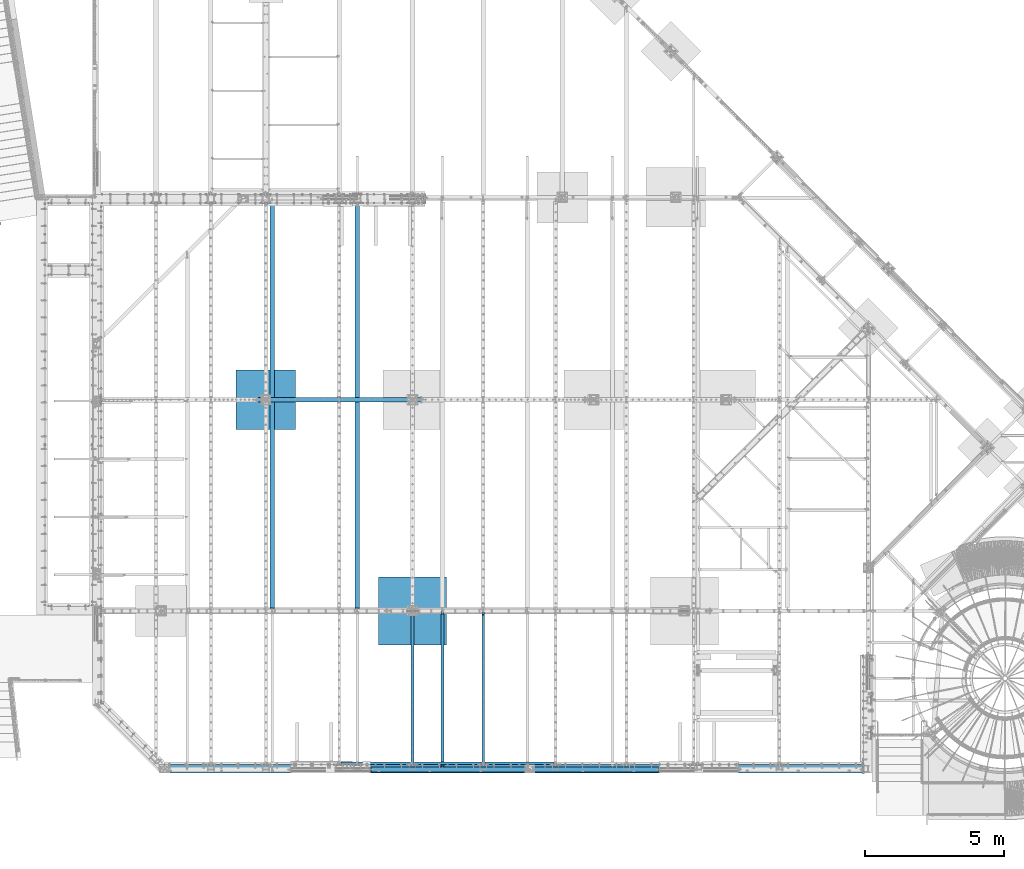
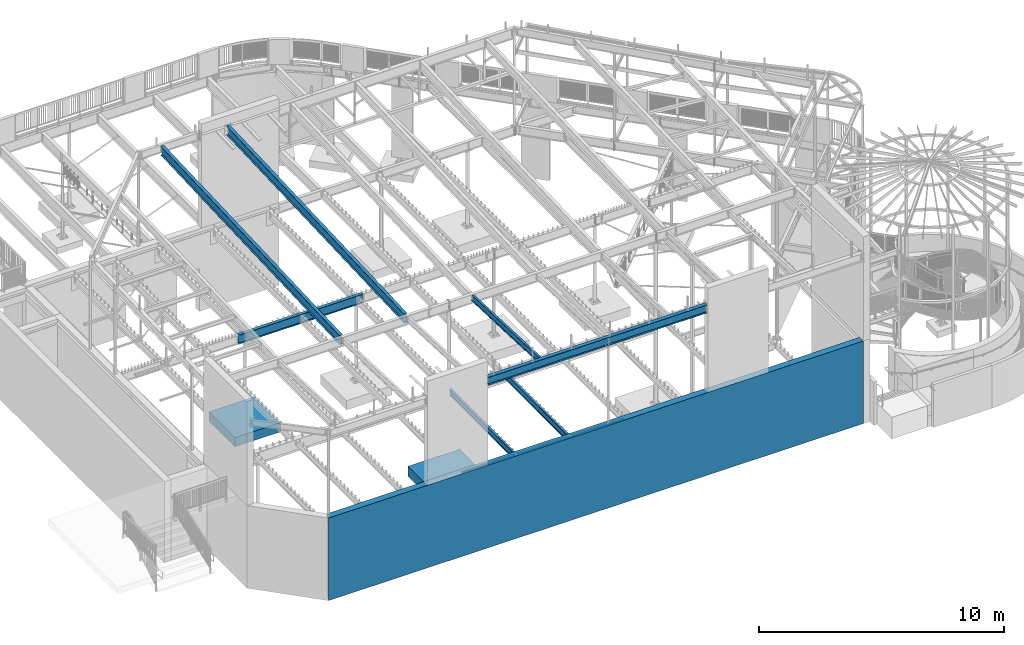
# One storey, part 313 of 975: 13 beams.
"""IFC2X3 building model written with IfcOpenShell, lengths in millimetres."""

from ifc_helpers import new_model, si_unit, frame, origin_with_axes, place, context, subcontext, project, spatial, faceted_brep, material, type_object, element, save


model = new_model("IFC2X3")

# Units and contexts
model_context = context("Model", 3, precision=1e-05, world=origin_with_axes())
body_context = subcontext(model_context, "Body", "Model", "MODEL_VIEW")
ifc_project = project(units=[si_unit("LENGTHUNIT", "METRE", prefix="MILLI"), si_unit("AREAUNIT", "SQUARE_METRE"), si_unit("VOLUMEUNIT", "CUBIC_METRE"), si_unit("MASSUNIT", "GRAM", prefix="KILO"), si_unit("TIMEUNIT", "SECOND"), si_unit("PLANEANGLEUNIT", "RADIAN"), si_unit("SOLIDANGLEUNIT", "STERADIAN"), si_unit("THERMODYNAMICTEMPERATUREUNIT", "DEGREE_CELSIUS"), si_unit("LUMINOUSINTENSITYUNIT", "LUMEN")], contexts=[model_context])

# Site, building, storey
site_placement = place(None, origin_with_axes())
site = spatial("IfcSite", under=ifc_project, at=site_placement, CompositionType="ELEMENT")
building_placement = place(site_placement, origin_with_axes())
building = spatial("IfcBuilding", under=site, at=building_placement, Name="Undefined", CompositionType="ELEMENT")
storey_placement = place(building_placement, origin_with_axes())
storey = spatial("IfcBuildingStorey", under=building, at=storey_placement, Name="Undefined", CompositionType="ELEMENT", Elevation=0.0)

# Beams
ifc_material_1 = material(Name="STEEL/A36")
beam_type_1 = type_object("IfcBeamType", Name="L4X4X5/16", PredefinedType="NOTDEFINED")
beam_1_placement = place(storey_placement, frame((16084.55, 355.599999999998, 3886.2), z_axis=(0.0, 0.0, -1.0), x_axis=(1.0, 0.0, 0.0)))
element("IfcBeam", 1, at=beam_1_placement, inside=storey, type_object=beam_type_1, material=ifc_material_1, Name="LEDGER_ANGLE", ObjectType="L4X4X5/16", context=body_context, shape_type="Brep", body=[
    faceted_brep([(-1.90993887372315e-11, 50.8000000000002, -50.8), (2.00088834390044e-11, 50.8000000000002, 50.8), (2470.15, 50.8, 50.8000000000002), (2470.15, 50.8, -50.8000000000002), (2.00088834390044e-11, 42.8625000000002, 50.8), (2470.15, 42.8625, 50.8000000000002), (-1.63709046319127e-11, 42.8625000000002, -42.8625), (2470.15, 42.8625, -42.8625000000002), (-1.63709046319127e-11, -50.8000000000002, -42.8625), (2470.15, -50.8, -42.8625000000002), (-1.90993887372315e-11, -50.8000000000002, -50.8), (2470.15, -50.8, -50.8000000000002)], [[[0, 1, 2, 3]], [[1, 4, 5, 2]], [[4, 6, 7, 5]], [[6, 8, 9, 7]], [[8, 10, 11, 9]], [[10, 0, 3, 11]], [[5, 7, 9, 11, 3, 2]], [[10, 8, 6, 4, 1, 0]]]),
])
beam_2_placement = place(storey_placement, frame((13550.9, 355.599999999995, 3886.2), z_axis=(0.0, 0.0, -1.0), x_axis=(1.0, 0.0, 0.0)))
element("IfcBeam", 2, at=beam_2_placement, inside=storey, type_object=beam_type_1, material=ifc_material_1, Name="LEDGER_ANGLE", ObjectType="L4X4X5/16", context=body_context, shape_type="Brep", body=[
    faceted_brep([(-1.90993887372315e-11, 50.8000000000002, -50.8), (2.00088834390044e-11, 50.8000000000002, 50.8), (2406.65, 50.8, 50.8000000000002), (2406.65, 50.8, -50.8000000000002), (2.00088834390044e-11, 42.8625000000002, 50.8), (2406.65, 42.8625, 50.8000000000002), (-1.63709046319127e-11, 42.8625000000002, -42.8625), (2406.65, 42.8625, -42.8625000000002), (-1.63709046319127e-11, -50.8000000000002, -42.8625), (2406.65, -50.8, -42.8625000000002), (-1.90993887372315e-11, -50.8000000000002, -50.8), (2406.65, -50.8, -50.8000000000002)], [[[0, 1, 2, 3]], [[1, 4, 5, 2]], [[4, 6, 7, 5]], [[6, 8, 9, 7]], [[8, 10, 11, 9]], [[10, 0, 3, 11]], [[5, 7, 9, 11, 3, 2]], [[10, 8, 6, 4, 1, 0]]]),
])
beam_3_placement = place(storey_placement, frame((10922.0, 355.599999999996, 3886.2), z_axis=(0.0, 0.0, -1.0), x_axis=(1.0, 0.0, 0.0)))
element("IfcBeam", 3, at=beam_3_placement, inside=storey, type_object=beam_type_1, material=ifc_material_1, Name="LEDGER_ANGLE", ObjectType="L4X4X5/16", context=body_context, shape_type="Brep", body=[
    faceted_brep([(-1.90993887372315e-11, 50.8000000000002, -50.8), (2.00088834390044e-11, 50.8000000000002, 50.8), (2501.9, 50.8, 50.8000000000002), (2501.9, 50.8, -50.8000000000002), (2.00088834390044e-11, 42.8625000000002, 50.8), (2501.9, 42.8625, 50.8000000000002), (-1.63709046319127e-11, 42.8625000000002, -42.8625), (2501.9, 42.8625, -42.8625000000002), (-1.63709046319127e-11, -50.8000000000002, -42.8625), (2501.9, -50.8, -42.8625000000002), (-1.90993887372315e-11, -50.8000000000002, -50.8), (2501.9, -50.8, -50.8000000000002)], [[[0, 1, 2, 3]], [[1, 4, 5, 2]], [[4, 6, 7, 5]], [[6, 8, 9, 7]], [[8, 10, 11, 9]], [[10, 0, 3, 11]], [[5, 7, 9, 11, 3, 2]], [[10, 8, 6, 4, 1, 0]]]),
])
ifc_material_2 = material(Name="STEEL/A992")
beam_type_2 = type_object("IfcBeamType", Name="W12X14", PredefinedType="NOTDEFINED")
beam_4_placement = place(storey_placement, frame((14557.375, 120.948825633107, 8307.50894703329), z_axis=(0.0, 0.0401238250036801, 0.999194715091645), x_axis=(0.0, 0.999194715091645, -0.0401238250036801)))
element("IfcBeam", 4, at=beam_4_placement, inside=storey, type_object=beam_type_2, material=ifc_material_2, Name="BEAM", ObjectType="W12X14", context=body_context, shape_type="Brep", body=[
    faceted_brep([(37.0520047015657, -2.38124999999854, -119.062500000143), (37.0520047015657, 2.38124999999854, -119.062500000143), (115.114860630816, 2.38124999999854, -119.062500000046), (115.114860630816, -2.38124999999854, -119.062500000046), (119.974940148861, 2.38124999999854, -120.029229922632), (119.974940148861, -2.38124999999854, -120.029229922632), (124.095116617013, 2.38124999999854, -122.78224382311), (124.095116617013, -2.38124999999854, -122.78224382311), (126.84813051749, 2.38124999999854, -126.902420291266), (126.84813051749, -2.38124999999854, -126.902420291266), (127.814860440076, -2.38124999999854, -131.762499809317), (127.814860440076, 2.38124999999854, -131.762499809317), (127.814860440082, 2.38124999999854, -144.462500000007), (127.814860440081, 50.7999999999993, -144.462500000007), (127.814860440083, 50.7999999999993, -150.812500000009), (127.814860440083, -50.7999999999993, -150.812500000009), (127.814860440082, -50.7999999999993, -144.462500000007), (127.814860440082, -2.38124999999854, -144.462500000007), (5581.66024242718, 50.7999999999993, 144.462500002061), (5581.66024242718, 2.38124999999854, 144.462500002061), (127.814860440073, 2.38124999999854, 144.4625000001), (127.814860440073, 50.7999999999993, 144.4625000001), (115.114860630788, -2.38124999999854, 119.062500000273), (115.114860630788, 2.38124999999854, 119.062500000273), (27.4898185884682, 2.38124999999854, 119.062500000271), (27.4898185884682, -2.38124999999854, 119.062500000271), (119.974940148833, -2.38124999999854, 120.029229922864), (119.974940148833, 2.38124999999854, 120.029229922864), (124.095116616988, -2.38124999999854, 122.782243823349), (124.095116616988, 2.38124999999854, 122.782243823349), (126.848130517467, -2.38124999999854, 126.902420291508), (126.848130517467, 2.38124999999854, 126.902420291508), (127.814860440057, -2.38124999999854, 131.76249980956), (127.814860440057, 2.38124999999854, 131.76249980956), (5581.66024242718, -50.7999999999993, 150.812500002065), (5581.66024242718, 50.7999999999993, 150.812500002065), (127.814860440071, 50.7999999999993, 150.812500000104), (127.814860440071, -50.7999999999993, 150.812499810841), (5581.66024242718, -50.7999999999993, 144.462500002061), (127.814860440073, -50.7999999999993, 144.4625000001), (5581.66024242718, -2.38124999999854, 144.462500002061), (127.814860440073, -2.38124999999854, 144.4625000001), (5581.66024242718, -2.38124999999854, 131.762499841927), (5581.66024242718, 2.38124999999854, 131.762499841927), (5582.62697234977, -2.38124999999854, 126.902420323875), (5582.62697234977, 2.38124999999854, 126.902420323875), (5585.37998625025, -2.38124999999854, 122.78224385572), (5585.37998625025, 2.38124999999854, 122.78224385572), (5589.5001627184, -2.38124999999854, 120.029229955242), (5589.5001627184, 2.38124999999854, 120.029229955242), (5594.36024223645, -2.38124999999854, 119.062500032656), (5594.36024223645, 2.38124999999854, 119.062500032656), (5672.42309816582, -2.38124999999854, 119.062500032685), (5672.42309816582, 2.38124999999854, 119.062500032685), (5683.00525079886, -2.38124999999854, -144.46249999801), (5683.00525079886, -50.7999999999993, -144.46249999801), (5683.26024242854, -50.7999999999993, -150.812499998011), (5683.26024242854, 50.7999999999993, -150.812499998011), (5683.00525079886, 50.7999999999993, -144.46249999801), (5683.00525079886, 2.38124999999854, -144.46249999801)], [[[0, 1, 2, 3]], [[3, 2, 4, 5]], [[5, 4, 6, 7]], [[7, 6, 8, 9]], [[10, 11, 12, 13, 14, 15, 16, 17]], [[9, 8, 11, 10]], [[18, 19, 20, 21]], [[22, 23, 24, 25]], [[26, 27, 23, 22]], [[28, 29, 27, 26]], [[30, 31, 29, 28]], [[32, 33, 31, 30]], [[34, 35, 36, 37]], [[38, 34, 37, 39]], [[40, 38, 39, 41]], [[37, 36, 21, 20, 33, 32, 41, 39]], [[35, 18, 21, 36]], [[34, 38, 40, 42, 43, 19, 18, 35]], [[44, 45, 43, 42]], [[46, 47, 45, 44]], [[48, 49, 47, 46]], [[50, 51, 49, 48]], [[52, 53, 51, 50]], [[54, 55, 56, 57, 58, 59, 53, 52]], [[55, 54, 17, 16]], [[56, 55, 16, 15]], [[57, 56, 15, 14]], [[58, 57, 14, 13]], [[59, 58, 13, 12]], [[6, 4, 2, 1, 24, 23, 27, 29, 31, 33, 20, 19, 43, 45, 47, 49, 51, 53, 59, 12, 11, 8]], [[25, 24, 1, 0]], [[54, 52, 50, 48, 46, 44, 42, 40, 41, 32, 30, 28, 26, 22, 25, 0, 3, 5, 7, 9, 10, 17]]]),
])
beam_type_3 = type_object("IfcBeamType", Name="W18X40", PredefinedType="NOTDEFINED")
beam_5_placement = place(storey_placement, frame((11509.375, 5829.11637334732, 8002.77977754136), z_axis=(0.0, -0.0411491589862163, 0.999153014665285), x_axis=(0.0, 0.999153014665285, 0.0411491589862177)))
element("IfcBeam", 5, at=beam_5_placement, inside=storey, type_object=beam_type_3, material=ifc_material_2, Name="BEAM", ObjectType="W18X40", context=body_context, shape_type="Brep", body=[
    faceted_brep([(14610.5022869476, -76.2000000000007, 214.312500005996), (14611.0253242716, -76.2000000000007, 227.012500005997), (109.117370300628, -76.2000000000007, 227.012500000065), (109.117370300622, -76.2000000000007, 214.312500000065), (14611.0253242716, 76.2000000000007, 227.012500005997), (109.117370300628, 76.2000000000007, 227.012500000065), (14610.5022869476, 76.2000000000007, 214.312500005996), (109.117370300622, 76.2000000000007, 214.312500000065), (14610.5022869476, 3.96875, 214.312500005996), (109.117370300622, 3.96875, 214.312500000065), (96.4173704913837, -3.96875, 195.262500000037), (96.4173704913837, 3.96875, 195.262500000037), (24.9083613255289, 3.96875, 195.262500000009), (24.9083613255289, -3.96875, 195.262500000009), (101.277450009429, -3.96875, 196.229229922624), (101.277450009429, 3.96875, 196.229229922624), (105.397626477584, -3.96875, 198.9822438231), (105.397626477584, 3.96875, 198.9822438231), (108.15064037806, -3.96875, 203.102420291253), (108.15064037806, 3.96875, 203.102420291253), (109.117370300646, -3.96875, 207.962499809298), (109.117370300646, 3.96875, 207.962499809298), (109.117370300622, -3.96875, 214.312500000065), (14610.5022869476, -3.96875, 214.312500005996), (14592.8497772603, 3.96875, -214.312499994047), (14592.8497772603, -3.96875, -214.312499994047), (14592.8497772603, -76.2000000000007, -214.312499994047), (14592.3267399362, -76.2000000000007, -227.01249999405), (14592.3267399362, 76.2000000000007, -227.01249999405), (14592.8497772603, 76.2000000000007, -214.312499994047), (71.0173703004093, -76.2000000000007, -214.312499999988), (71.0173703004148, -76.2000000000007, -227.012499809476), (71.0173703004139, 76.2000000000007, -227.012499999989), (71.0173703004093, 76.2000000000007, -214.312499999988), (71.0173703004093, 3.96875, -214.312499999988), (67.2976264773361, 3.96875, -198.982243823111), (63.1774500091806, 3.96875, -196.229229922636), (58.3173704911333, 3.96875, -195.262500000049), (8.8249636104365, 3.96875, -195.262500000069), (71.0173703004075, 3.96875, -207.962499809312), (70.0506403778163, 3.96875, -203.102420291266), (8.8249636104365, -3.96875, -195.262500000069), (58.3173704911333, -3.96875, -195.262500000049), (63.1774500091806, -3.96875, -196.229229922636), (67.2976264773361, -3.96875, -198.982243823111), (70.0506403778163, -3.96875, -203.102420291266), (71.0173703004075, -3.96875, -207.962499809312), (71.0173703004093, -3.96875, -214.312499999988)], [[[0, 1, 2, 3]], [[1, 4, 5, 2]], [[4, 6, 7, 5]], [[6, 8, 9, 7]], [[10, 11, 12, 13]], [[14, 15, 11, 10]], [[16, 17, 15, 14]], [[18, 19, 17, 16]], [[20, 21, 19, 18]], [[2, 5, 7, 9, 21, 20, 22, 3]], [[23, 0, 3, 22]], [[24, 8, 6, 4, 1, 0, 23, 25, 26, 27, 28, 29]], [[27, 26, 30, 31]], [[28, 27, 31, 32]], [[29, 28, 32, 33]], [[24, 29, 33, 34]], [[35, 36, 37, 38, 12, 11, 15, 17, 19, 21, 9, 8, 24, 34, 39, 40]], [[13, 12, 38, 41]], [[25, 23, 22, 20, 18, 16, 14, 10, 13, 41, 42, 43, 44, 45, 46, 47]], [[26, 25, 47, 30]], [[46, 39, 34, 33, 32, 31, 30, 47]], [[45, 40, 39, 46]], [[44, 35, 40, 45]], [[43, 36, 35, 44]], [[42, 37, 36, 43]], [[41, 38, 37, 42]]]),
])
beam_6_placement = place(storey_placement, frame((8461.375, 5829.11637334778, 8002.77977754138), z_axis=(0.0, -0.0411491589862163, 0.999153014665285), x_axis=(0.0, 0.999153014665285, 0.0411491589862177)))
element("IfcBeam", 6, at=beam_6_placement, inside=storey, type_object=beam_type_3, material=ifc_material_2, Name="BEAM", ObjectType="W18X40", context=body_context, shape_type="Brep", body=[
    faceted_brep([(14687.3760459586, -3.96875, -214.312499994008), (14687.3760459586, -76.2000000000007, -214.312499994008), (14687.3760459585, -76.2000000000007, -227.012499992935), (14687.3760459585, 76.2000000000007, -227.01249999401), (14687.3760459586, 76.2000000000007, -214.312499994008), (14687.3760459586, 3.96875, -214.312499994008), (14687.3760459587, 3.96875, -150.812499688427), (14687.3760459587, -3.96875, -150.812499688427), (14688.3427758813, 3.96875, -145.952420170393), (14688.3427758813, -3.96875, -145.952420170393), (14691.0957897818, 3.96875, -141.83224370225), (14691.0957897818, -3.96875, -141.83224370225), (14695.2159662499, 3.96875, -139.079229801778), (14695.2159662499, -3.96875, -139.079229801778), (14700.0760457679, 3.96875, -138.112499879187), (14700.0760457679, -3.96875, -138.112499879187), (14773.9387228735, -3.96875, -138.112499879256), (14773.9387228735, 3.96875, -138.112499879256), (109.117370300622, 3.96875, 214.312500000065), (109.117370300622, 76.2000000000007, 214.312500000065), (14687.3760459597, 76.2000000000007, 214.312500006027), (14687.3760459597, 3.96875, 214.312500006027), (71.0173703004075, -3.96875, -207.962499809312), (71.0173703004075, 3.96875, -207.962499809312), (71.0173703004093, 3.96875, -214.312499999988), (71.0173703004093, 76.2000000000007, -214.312499999988), (71.0173703004139, 76.2000000000007, -227.012499999989), (71.0173703004148, -76.2000000000007, -227.012499809476), (71.0173703004093, -76.2000000000007, -214.312499999988), (71.0173703004093, -3.96875, -214.312499999988), (70.0506403778163, -3.96875, -203.102420291266), (70.0506403778163, 3.96875, -203.102420291266), (67.2976264773361, -3.96875, -198.982243823111), (67.2976264773361, 3.96875, -198.982243823111), (63.1774500091806, -3.96875, -196.229229922636), (63.1774500091806, 3.96875, -196.229229922636), (58.3173704911333, -3.96875, -195.262500000049), (58.3173704911333, 3.96875, -195.262500000049), (8.8249636104365, -3.96875, -195.262500000069), (8.8249636104365, 3.96875, -195.262500000069), (24.9083613255289, -3.96875, 195.262500000009), (24.9083613255289, 3.96875, 195.262500000009), (96.4173704913837, -3.96875, 195.262500000037), (96.4173704913837, 3.96875, 195.262500000037), (101.277450009429, -3.96875, 196.229229922624), (101.277450009429, 3.96875, 196.229229922624), (105.397626477584, -3.96875, 198.9822438231), (105.397626477584, 3.96875, 198.9822438231), (108.15064037806, -3.96875, 203.102420291253), (108.15064037806, 3.96875, 203.102420291253), (109.117370300646, -3.96875, 207.962499809298), (109.117370300646, 3.96875, 207.962499809298), (109.117370300628, -76.2000000000007, 227.012500000065), (109.117370300628, 76.2000000000007, 227.012500000065), (109.117370300622, -3.96875, 214.312500000065), (109.117370300622, -76.2000000000007, 214.312500000065), (14687.3760459597, -3.96875, 214.312500006027), (14687.3760459597, -76.2000000000007, 214.312500006027), (14687.3760459597, -76.2000000000007, 227.012500006028), (14687.3760459597, 76.2000000000007, 227.012500006028), (14687.3760459597, -3.96875, 207.962499930165), (14687.3760459597, 3.96875, 207.962499930165), (14688.3427758823, -3.96875, 203.102420412109), (14688.3427758823, 3.96875, 203.102420412109), (14691.0957897828, -3.96875, 198.982243943945), (14691.0957897828, 3.96875, 198.982243943945), (14695.215966251, -3.96875, 196.229230043458), (14695.215966251, 3.96875, 196.229230043458), (14700.076045769, -3.96875, 195.262500120864), (14700.076045769, 3.96875, 195.262500120864), (14787.6684526303, -3.96875, 195.262500120981), (14787.6684526303, 3.96875, 195.262500120981)], [[[0, 1, 2, 3, 4, 5, 6, 7]], [[7, 6, 8, 9]], [[9, 8, 10, 11]], [[11, 10, 12, 13]], [[13, 12, 14, 15]], [[16, 15, 14, 17]], [[18, 19, 20, 21]], [[22, 23, 24, 25, 26, 27, 28, 29]], [[30, 31, 23, 22]], [[32, 33, 31, 30]], [[34, 35, 33, 32]], [[36, 37, 35, 34]], [[38, 39, 37, 36]], [[40, 41, 39, 38]], [[42, 43, 41, 40]], [[44, 45, 43, 42]], [[46, 47, 45, 44]], [[48, 49, 47, 46]], [[50, 51, 49, 48]], [[52, 53, 19, 18, 51, 50, 54, 55]], [[55, 54, 56, 57]], [[52, 55, 57, 58]], [[53, 52, 58, 59]], [[19, 53, 59, 20]], [[58, 57, 56, 60, 61, 21, 20, 59]], [[62, 63, 61, 60]], [[64, 65, 63, 62]], [[66, 67, 65, 64]], [[68, 69, 67, 66]], [[70, 71, 69, 68]], [[71, 70, 16, 17]], [[12, 10, 8, 6, 5, 24, 23, 31, 33, 35, 37, 39, 41, 43, 45, 47, 49, 51, 18, 21, 61, 63, 65, 67, 69, 71, 17, 14]], [[25, 24, 5, 4]], [[26, 25, 4, 3]], [[27, 26, 3, 2]], [[28, 27, 2, 1]], [[29, 28, 1, 0]], [[70, 68, 66, 64, 62, 60, 56, 54, 50, 48, 46, 44, 42, 40, 38, 36, 34, 32, 30, 22, 29, 0, 7, 9, 11, 13, 15, 16]]]),
])
beam_type_4 = type_object("IfcBeamType", Name="W16X36", PredefinedType="NOTDEFINED")
beam_7_placement = place(storey_placement, frame((11972.9250113505, 127.0, 8256.5875), z_axis=(0.0, 0.0, -1.0), x_axis=(1.0, 0.0, 0.0)))
element("IfcBeam", 7, at=beam_7_placement, inside=storey, type_object=beam_type_4, material=ifc_material_2, Name="BEAM", ObjectType="W16X36", context=body_context, shape_type="Brep", body=[
    faceted_brep([(25.3999999999996, -88.9, -201.612499999999), (25.3999999999996, 88.9, -201.612499999999), (10337.8000013495, 88.9, -201.612499999999), (10337.8000013495, -88.9, -201.612499999999), (25.3999999999996, -88.9, -190.5), (25.3999999999996, -3.96875, -190.5), (25.3999999999996, -3.96875, 190.5), (25.3999999999996, -88.9, 190.5), (25.3999999999996, -88.9, 201.6125), (25.3999999999996, 88.9, 201.6125), (25.3999999999996, 88.9, 190.5), (25.3999999999996, 3.96875, 190.5), (25.3999999999996, 3.96875, -190.5), (25.3999999999996, 88.9, -190.5), (10337.8000013495, -88.9, -190.5), (10337.8000013495, -3.96875, -190.5), (10337.8000013495, -3.96875, 190.5), (10337.8000013495, -88.9, 190.5), (10337.8000013495, -88.9, 201.6125), (10337.8000013495, 88.9, 201.6125), (10337.8000013495, 88.9, 190.5), (10337.8000013495, 3.96875, 190.5), (10337.8000013495, 3.96875, -190.5), (10337.8000013495, 88.9, -190.5)], [[[0, 1, 2, 3]], [[0, 4, 5, 6, 7, 8, 9, 10, 11, 12, 13, 1]], [[5, 4, 14, 15]], [[6, 5, 15, 16]], [[7, 6, 16, 17]], [[8, 7, 17, 18]], [[9, 8, 18, 19]], [[10, 9, 19, 20]], [[11, 10, 20, 21]], [[12, 11, 21, 22]], [[13, 12, 22, 23]], [[1, 13, 23, 2]], [[22, 21, 20, 19, 18, 17, 16, 15, 14, 3, 2, 23]], [[4, 0, 3, 14]]]),
])
beam_type_5 = type_object("IfcBeamType", Name="W18X35", PredefinedType="NOTDEFINED")
beam_8_placement = place(storey_placement, frame((7918.45, 13392.15, 3711.575), z_axis=(0.0, 0.0, 1.0), x_axis=(1.0, 0.0, 0.0)))
element("IfcBeam", 8, at=beam_8_placement, inside=storey, type_object=beam_type_5, material=ifc_material_2, Name="BEAM", ObjectType="W18X35", context=body_context, shape_type="Brep", body=[
    faceted_brep([(14.287031462678, -76.1999999999998, 225.425), (14.287031462678, 76.1999999999998, 225.425), (3.17496870515606, 76.1999999999998, 214.312499999999), (3.17496870515606, 3.96875, 214.312499999999), (2.77798382235414, 3.96875, 213.915499496458), (2.77798382235414, -3.96875, 213.915499496458), (3.17496870515606, -3.96875, 214.312499999999), (3.17496870515606, -76.1999999999998, 214.312499999999), (22.2250007629409, -3.96875, 213.915499496458), (22.2250007629409, 3.96875, 213.915499496458), (40.7122683048001, 3.96875, 203.575605287907), (40.7122683048001, -3.96875, 203.575605287907), (44.8249534620081, 3.96875, 198.997422721183), (44.8249534620081, -3.96875, 198.997422721183), (45.2798117862694, 3.96875, 192.860074863892), (45.2798117862694, -3.96875, 192.860074863892), (41.8869600345242, 3.96875, 187.725633140859), (41.8869600345242, -3.96875, 187.725633140859), (36.0627638298283, 3.96875, 185.737499999999), (36.0627638298283, -3.96875, 185.737499999999), (6.34999999999854, 3.96875, 185.737499999999), (6.34999999999854, -3.96875, 185.737499999999), (6.34999999999854, 3.96875, -185.7375), (6.34999999999854, -3.96875, -185.7375), (47.9687625480874, 3.96875, -185.7375), (47.9687625480874, -3.96875, -185.7375), (53.7929587527833, 3.96875, -187.72563314086), (53.7929587527833, -3.96875, -187.72563314086), (57.1858105045285, 3.96875, -192.860074863893), (57.1858105045285, -3.96875, -192.860074863893), (56.7309521802672, 3.96875, -198.997422721185), (56.7309521802672, -3.96875, -198.997422721185), (52.6182670230592, 3.96875, -203.575605287907), (52.6182670230592, -3.96875, -203.575605287907), (34.1309994812, 3.96875, -213.91549949646), (34.1309994812, -3.96875, -213.91549949646), (14.6840158801024, 3.96875, -213.91549949646), (14.6840158801024, -3.96875, -213.91549949646), (5865.8129690027, 3.96875, -214.3125), (5865.8129690027, 76.2000000000007, -214.3125), (14.2870309973041, 76.1999999999998, -214.3125), (14.2870309973041, 3.96875, -214.3125), (5876.92503176022, 76.2000000000007, -225.425), (3.17496823977854, 76.1999999999998, -225.425), (5876.92503176022, -76.2000000000007, -225.425), (3.17496823977854, -76.1999999999998, -225.425), (5865.8129690027, -76.2000000000007, -214.3125), (14.2870309973041, -76.1999999999998, -214.3125), (14.2870309973041, -3.96875, -214.3125), (5865.8129690027, -3.96875, -214.3125), (5865.4159841199, 3.96875, -213.91549949646), (5865.4159841199, -3.96875, -213.91549949646), (5845.9690005188, 3.96875, -213.91549949646), (5845.9690005188, -3.96875, -213.91549949646), (5827.48173297694, 3.96875, -203.575605287907), (5827.48173297694, -3.96875, -203.575605287907), (5823.36904781973, 3.96875, -198.997422721185), (5823.36904781973, -3.96875, -198.997422721185), (5822.91418949547, 3.96875, -192.860074863893), (5822.91418949547, -3.96875, -192.860074863893), (5826.30704124722, 3.96875, -187.72563314086), (5826.30704124722, -3.96875, -187.72563314086), (5832.13123745191, 3.96875, -185.7375), (5832.13123745191, -3.96875, -185.7375), (5873.75, 3.96875, -185.7375), (5873.75, -3.96875, -185.7375), (5873.75, -3.96875, 185.7375), (5873.75, 3.96875, 185.7375), (5844.03723617017, 3.96875, 185.7375), (5844.03723617017, -3.96875, 185.7375), (5838.21303996548, 3.96875, 187.72563314086), (5838.21303996548, -3.96875, 187.72563314086), (5834.82018821373, 3.96875, 192.860074863893), (5834.82018821373, -3.96875, 192.860074863893), (5835.27504653799, 3.96875, 198.997422721185), (5835.27504653799, -3.96875, 198.997422721185), (5839.3877316952, 3.96875, 203.575605287907), (5839.3877316952, -3.96875, 203.575605287907), (5857.87499923706, 3.96875, 213.91549949646), (5857.87499923706, -3.96875, 213.91549949646), (5877.32201617765, 3.96875, 213.91549949646), (5877.32201617765, -3.96875, 213.91549949646), (5876.92503129485, 3.96875, 214.3125), (5876.92503129485, 76.2000000000007, 214.3125), (5865.81296853732, 76.2000000000007, 225.425), (5865.81296853732, -76.2000000000007, 225.425), (5876.92503129485, -76.2000000000007, 214.3125), (5876.92503129485, -3.96875, 214.3125)], [[[0, 1, 2, 3, 4, 5, 6, 7]], [[8, 9, 10, 11]], [[11, 10, 12, 13]], [[13, 12, 14, 15]], [[15, 14, 16, 17]], [[17, 16, 18, 19]], [[19, 18, 20, 21]], [[21, 20, 22, 23]], [[24, 25, 23, 22]], [[25, 24, 26, 27]], [[27, 26, 28, 29]], [[29, 28, 30, 31]], [[31, 30, 32, 33]], [[33, 32, 34, 35]], [[35, 34, 36, 37]], [[38, 39, 40, 41]], [[39, 42, 43, 40]], [[42, 44, 45, 43]], [[44, 46, 47, 45]], [[37, 36, 41, 40, 43, 45, 47, 48]], [[46, 49, 48, 47]], [[44, 42, 39, 38, 50, 51, 49, 46]], [[52, 53, 51, 50]], [[53, 52, 54, 55]], [[55, 54, 56, 57]], [[57, 56, 58, 59]], [[59, 58, 60, 61]], [[61, 60, 62, 63]], [[63, 62, 64, 65]], [[66, 65, 64, 67]], [[68, 69, 66, 67]], [[69, 68, 70, 71]], [[71, 70, 72, 73]], [[73, 72, 74, 75]], [[75, 74, 76, 77]], [[77, 76, 78, 79]], [[79, 78, 80, 81]], [[81, 80, 82, 83, 84, 85, 86, 87]], [[86, 85, 0, 7]], [[87, 86, 7, 6]], [[8, 11, 13, 15, 17, 19, 21, 23, 25, 27, 29, 31, 33, 35, 37, 48, 49, 51, 53, 55, 57, 59, 61, 63, 65, 66, 69, 71, 73, 75, 77, 79, 81, 87, 6, 5]], [[9, 8, 5, 4]], [[82, 80, 78, 76, 74, 72, 70, 68, 67, 64, 62, 60, 58, 56, 54, 52, 50, 38, 41, 36, 34, 32, 30, 28, 26, 24, 22, 20, 18, 16, 14, 12, 10, 9, 4, 3]], [[83, 82, 3, 2]], [[84, 83, 2, 1]], [[85, 84, 1, 0]]]),
])
ifc_material_3 = material(Name="CONCRETE/5000")
beam_type_6 = type_object("IfcBeamType", PredefinedType="NOTDEFINED")
beam_9_placement = place(storey_placement, frame((4454.5251953125, 152.4, 2057.4), z_axis=(0.0, 0.0, 1.0), x_axis=(1.0, 0.0, 0.0)))
element("IfcBeam", 9, at=beam_9_placement, inside=storey, type_object=beam_type_6, material=ifc_material_3, Name="WALL", context=body_context, shape_type="Brep", body=[
    faceted_brep([(126.252310491574, 152.400000000026, -2057.4), (126.252310491574, 152.400000000026, 2057.4), (25199.9748046875, 152.4, 2057.4), (25199.9748046875, 152.4, -2057.4), (-4.33680868994202e-19, -152.400000000009, 2057.4), (25199.9748046875, -152.4, 2057.4), (-4.33680868994202e-19, -152.400000000009, -2057.4), (25199.9748046875, -152.4, -2057.4)], [[[0, 1, 2, 3]], [[1, 4, 5, 2]], [[4, 6, 7, 5]], [[6, 0, 3, 7]], [[5, 7, 3, 2]], [[6, 4, 1, 0]]]),
])
beam_type_7 = type_object("IfcBeamType", Name="W12X19", PredefinedType="NOTDEFINED")
beam_10_placement = place(storey_placement, frame((16021.05, 114.300000000004, 3783.0125), z_axis=(0.0, 0.0, 1.0), x_axis=(0.0, 1.0, 0.0)))
element("IfcBeam", 10, at=beam_10_placement, inside=storey, type_object=beam_type_7, material=ifc_material_2, Name="BEAM", ObjectType="W12X19", context=body_context, shape_type="Brep", body=[
    faceted_brep([(215.899999999996, -3.17499999999927, -144.4625), (215.899999999996, -50.7999999999993, -144.4625), (5674.51874999999, -50.7999999999993, -144.4625), (5674.51874999999, -3.17499999999927, -144.4625), (215.899999999996, -50.7999999999993, -153.9875), (5674.51874999999, -50.7999999999993, -153.9875), (215.899999999996, 50.7999999999993, -153.9875), (5674.51874999999, 50.7999999999993, -153.9875), (215.899999999996, 50.7999999999993, -144.4625), (215.899999999996, 3.17499999999927, -144.4625), (5674.51874999999, 3.17499999999927, -144.4625), (5674.51874999999, 50.7999999999993, -144.4625), (5674.51874999999, 3.17499999999927, 128.5875), (5674.51874999999, -3.17499999999927, 128.5875), (215.899999999996, -3.17499999999927, 144.4625), (215.899999999996, -50.7999999999993, 144.4625), (215.899999999996, -50.7999999999993, 153.9875), (215.899999999996, 50.7999999999993, 153.9875), (215.899999999996, 50.7999999999993, 144.4625), (215.899999999996, 3.17499999999927, 144.4625), (5566.56874999999, 50.7999999999993, 144.4625), (5566.56874999999, 3.17499999999927, 144.4625), (5566.56874999999, 3.17499999999927, 141.287499809265), (5567.53547992258, 3.17499999999927, 136.42742029122), (5570.28849382306, 3.17499999999927, 132.307243823066), (5574.40867029121, 3.17499999999927, 129.554229922588), (5579.26874980926, 3.17499999999927, 128.5875), (5567.53547992258, -3.17499999999927, 136.42742029122), (5566.56874999999, -3.17499999999927, 141.287499809265), (5570.28849382306, -3.17499999999927, 132.307243823066), (5574.40867029121, -3.17499999999927, 129.554229922588), (5579.26874980926, -3.17499999999927, 128.5875), (5566.56874999999, -3.17499999999927, 144.4625), (5566.56874999999, -50.7999999999993, 144.4625), (5566.56874999999, -50.7999999999993, 153.9875), (5566.56874999999, 50.7999999999993, 153.9875)], [[[0, 1, 2, 3]], [[1, 4, 5, 2]], [[4, 6, 7, 5]], [[8, 9, 10, 11]], [[3, 2, 5, 7, 11, 10, 12, 13]], [[6, 8, 11, 7]], [[4, 1, 0, 14, 15, 16, 17, 18, 19, 9, 8, 6]], [[19, 18, 20, 21]], [[10, 9, 19, 21, 22, 23, 24, 25, 26, 12]], [[27, 23, 22, 28]], [[29, 24, 23, 27]], [[30, 25, 24, 29]], [[31, 26, 25, 30]], [[13, 12, 26, 31]], [[30, 29, 27, 28, 32, 14, 0, 3, 13, 31]], [[15, 14, 32, 33]], [[16, 15, 33, 34]], [[17, 16, 34, 35]], [[18, 17, 35, 20]], [[34, 33, 32, 28, 22, 21, 20, 35]]]),
])
beam_11_placement = place(storey_placement, frame((13487.4, 114.3, 3783.0125), z_axis=(0.0, 0.0, 1.0), x_axis=(0.0, 1.0, 0.0)))
element("IfcBeam", 11, at=beam_11_placement, inside=storey, type_object=beam_type_7, material=ifc_material_2, Name="BEAM", ObjectType="W12X19", context=body_context, shape_type="Brep", body=[
    faceted_brep([(215.899999999996, -50.7999999999993, -153.9875), (215.899999999996, 50.7999999999993, -153.9875), (5595.874, 50.7999999999993, -153.9875), (5595.874, -50.7999999999993, -153.9875), (215.899999999996, -50.7999999999993, -144.4625), (215.899999999996, -3.17499999999927, -144.4625), (215.899999999996, -3.17499999999927, 144.4625), (215.899999999996, -50.7999999999993, 144.4625), (215.899999999996, -50.7999999999993, 153.9875), (215.899999999996, 50.7999999999993, 153.9875), (215.899999999996, 50.7999999999993, 144.4625), (215.899999999996, 3.17499999999927, 144.4625), (215.899999999996, 3.17499999999927, -144.4625), (215.899999999996, 50.7999999999993, -144.4625), (5595.874, -50.7999999999993, -144.4625), (5595.874, -3.17499999999927, -144.4625), (5595.874, -3.17499999999927, 144.4625), (5595.874, -50.7999999999993, 144.4625), (5595.874, -50.7999999999993, 153.9875), (5595.874, 50.7999999999993, 153.9875), (5595.874, 50.7999999999993, 144.4625), (5595.874, 3.17499999999927, 144.4625), (5595.874, 3.17499999999927, -144.4625), (5595.874, 50.7999999999993, -144.4625)], [[[0, 1, 2, 3]], [[0, 4, 5, 6, 7, 8, 9, 10, 11, 12, 13, 1]], [[5, 4, 14, 15]], [[6, 5, 15, 16]], [[7, 6, 16, 17]], [[8, 7, 17, 18]], [[9, 8, 18, 19]], [[10, 9, 19, 20]], [[11, 10, 20, 21]], [[12, 11, 21, 22]], [[13, 12, 22, 23]], [[1, 13, 23, 2]], [[22, 21, 20, 19, 18, 17, 16, 15, 14, 3, 2, 23]], [[4, 0, 3, 14]]]),
])
beam_type_8 = type_object("IfcBeamType", PredefinedType="NOTDEFINED")
beam_12_placement = place(storey_placement, frame((12268.2, 5819.775023622, -558.799999999999), z_axis=(0.0, 0.0, 1.0), x_axis=(1.0, 0.0, 0.0)))
element("IfcBeam", 12, at=beam_12_placement, inside=storey, type_object=beam_type_8, material=ifc_material_3, Name="FOOTING", context=body_context, shape_type="Brep", body=[
    faceted_brep([(0.0, 1219.2, -254.0), (0.0, 1219.2, 254.0), (2438.4, 1219.2, 254.0), (2438.4, 1219.2, -254.0), (0.0, -1219.2, 254.0), (2438.4, -1219.2, 254.0), (0.0, -1219.2, -254.0), (2438.4, -1219.2, -254.0)], [[[0, 1, 2, 3]], [[1, 4, 5, 2]], [[4, 6, 7, 5]], [[6, 0, 3, 7]], [[5, 7, 3, 2]], [[6, 4, 1, 0]]]),
])
beam_type_9 = type_object("IfcBeamType", PredefinedType="NOTDEFINED")
beam_13_placement = place(storey_placement, frame((7162.79999389648, 13392.15, -533.4), z_axis=(0.0, 0.0, 1.0), x_axis=(1.0, 0.0, 0.0)))
element("IfcBeam", 13, at=beam_13_placement, inside=storey, type_object=beam_type_9, material=ifc_material_3, Name="FOOTING", context=body_context, shape_type="Brep", body=[
    faceted_brep([(0.0, 1066.8, -228.6), (0.0, 1066.8, 228.6), (2133.6, 1066.8, 228.6), (2133.6, 1066.8, -228.6), (0.0, -1066.8, 228.6), (2133.6, -1066.8, 228.6), (0.0, -1066.8, -228.6), (2133.6, -1066.8, -228.6)], [[[0, 1, 2, 3]], [[1, 4, 5, 2]], [[4, 6, 7, 5]], [[6, 0, 3, 7]], [[5, 7, 3, 2]], [[6, 4, 1, 0]]]),
])

save(model, "model.ifc")
